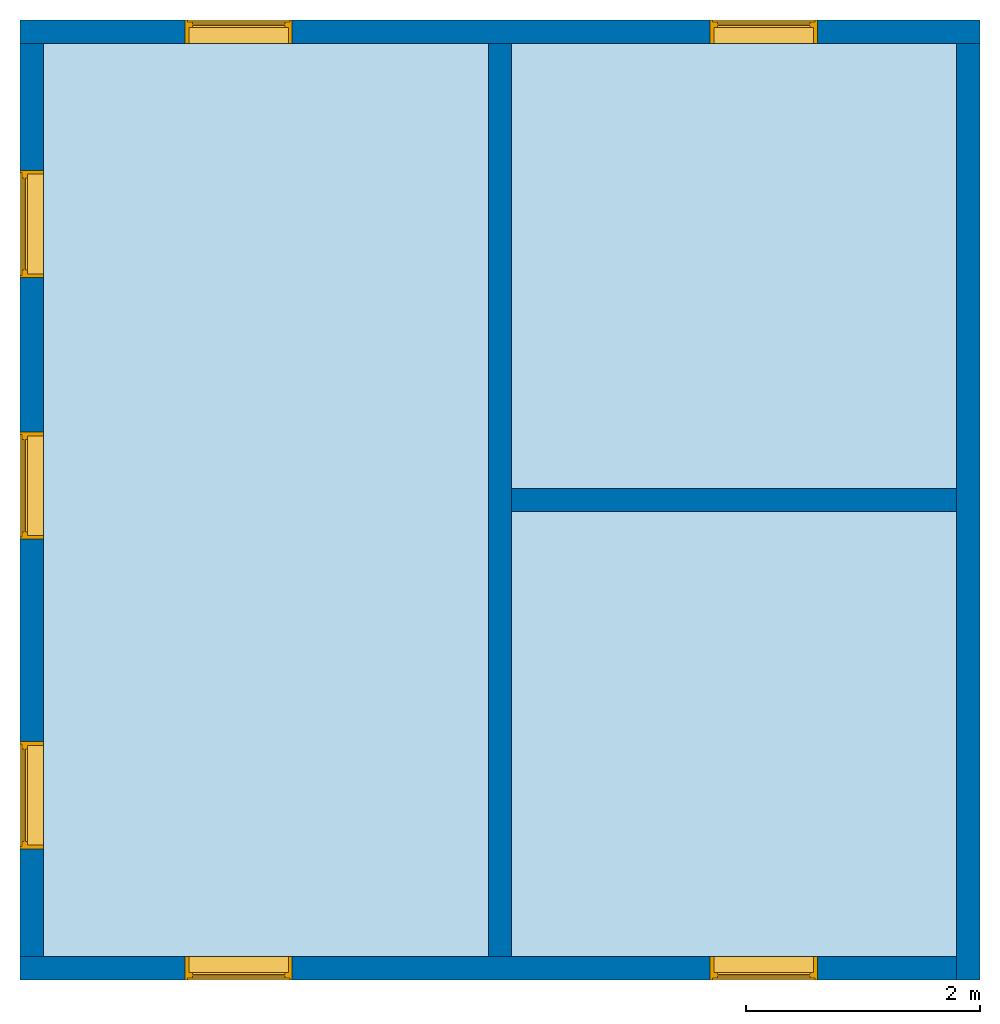
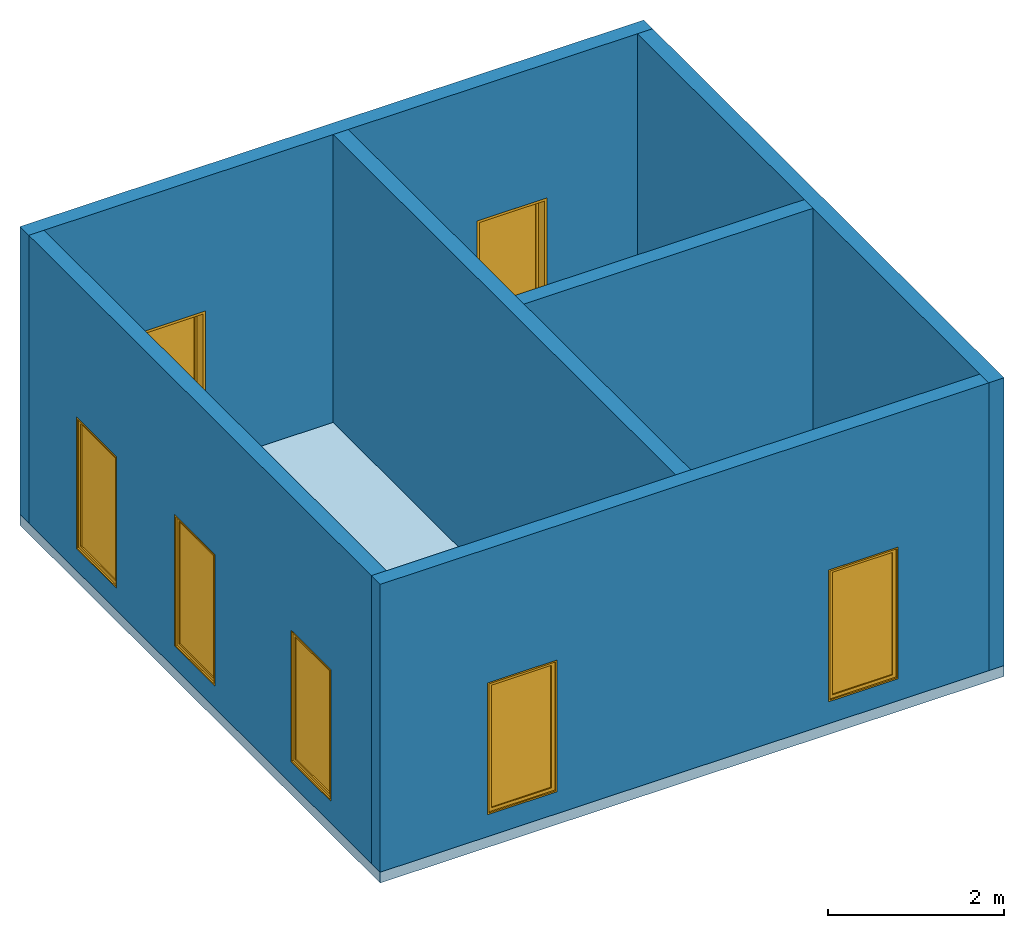
# One storey: 7 windows, 6 walls, 1 slab, 7 openings.
"""IFC2X3 building model written with IfcOpenShell, lengths in millimetres."""

from ifc_helpers import new_model, entity, si_unit, converted_unit, derived_unit, direction, frame, frame_2d, origin, place, context, subcontext, project, spatial, polyline, rectangle, outline, extrude, clip, halfspace, source, transform, mapped, material, material_list, layer, layer_set, layer_usage, type_object, type_shapes, element, fill, save


model = new_model("IFC2X3")

# Units and contexts
model_context = context("Model", 3, precision=0.01, world=origin(), true_north=direction((6.12303176911189e-17, 1.0)))
body_context = subcontext(model_context, "Body", "Model", "MODEL_VIEW")
ifc_project = project(units=[si_unit("LENGTHUNIT", "METRE", prefix="MILLI"), si_unit("AREAUNIT", "SQUARE_METRE"), si_unit("VOLUMEUNIT", "CUBIC_METRE"), converted_unit("PLANEANGLEUNIT", "DEGREE", entity("IfcRatioMeasure", 0.0174532925199433), si_unit("PLANEANGLEUNIT", "RADIAN"), dimensions=[0, 0, 0, 0, 0, 0, 0]), si_unit("MASSUNIT", "GRAM", prefix="KILO"), derived_unit("MASSDENSITYUNIT", [(si_unit("MASSUNIT", "GRAM", prefix="KILO"), 1), (si_unit("LENGTHUNIT", "METRE"), -3)]), derived_unit("MOMENTOFINERTIAUNIT", [(si_unit("LENGTHUNIT", "METRE"), 4)]), si_unit("TIMEUNIT", "SECOND"), si_unit("FREQUENCYUNIT", "HERTZ"), si_unit("THERMODYNAMICTEMPERATUREUNIT", "DEGREE_CELSIUS"), derived_unit("THERMALTRANSMITTANCEUNIT", [(si_unit("MASSUNIT", "GRAM", prefix="KILO"), 1), (si_unit("THERMODYNAMICTEMPERATUREUNIT", "KELVIN"), -1), (si_unit("TIMEUNIT", "SECOND"), -3)]), derived_unit("VOLUMETRICFLOWRATEUNIT", [(si_unit("LENGTHUNIT", "METRE"), 3), (si_unit("TIMEUNIT", "SECOND"), -1)]), si_unit("ELECTRICCURRENTUNIT", "AMPERE"), si_unit("ELECTRICVOLTAGEUNIT", "VOLT"), si_unit("POWERUNIT", "WATT"), si_unit("FORCEUNIT", "NEWTON", prefix="KILO"), si_unit("ILLUMINANCEUNIT", "LUX"), si_unit("LUMINOUSFLUXUNIT", "LUMEN"), si_unit("LUMINOUSINTENSITYUNIT", "CANDELA"), derived_unit("USERDEFINED", [(si_unit("MASSUNIT", "GRAM", prefix="KILO"), -1), (si_unit("LENGTHUNIT", "METRE"), -2), (si_unit("TIMEUNIT", "SECOND"), 3), (si_unit("LUMINOUSFLUXUNIT", "LUMEN"), 1)]), derived_unit("LINEARVELOCITYUNIT", [(si_unit("LENGTHUNIT", "METRE"), 1), (si_unit("TIMEUNIT", "SECOND"), -1)]), si_unit("PRESSUREUNIT", "PASCAL"), derived_unit("USERDEFINED", [(si_unit("LENGTHUNIT", "METRE"), -2), (si_unit("MASSUNIT", "GRAM", prefix="KILO"), 1), (si_unit("TIMEUNIT", "SECOND"), -2)]), derived_unit("LINEARFORCEUNIT", [(si_unit("MASSUNIT", "GRAM", prefix="KILO"), 1), (si_unit("LENGTHUNIT", "METRE"), 1), (si_unit("TIMEUNIT", "SECOND"), -2), (si_unit("LENGTHUNIT", "METRE"), -1)]), derived_unit("PLANARFORCEUNIT", [(si_unit("MASSUNIT", "GRAM", prefix="KILO"), 1), (si_unit("LENGTHUNIT", "METRE"), 1), (si_unit("TIMEUNIT", "SECOND"), -2), (si_unit("LENGTHUNIT", "METRE"), -2)])], contexts=[model_context])

# Site, building, storey
site_placement = place(None, origin())
site = spatial("IfcSite", under=ifc_project, at=site_placement, CompositionType="ELEMENT")
building_placement = place(site_placement, origin())
building = spatial("IfcBuilding", under=site, at=building_placement, Name="// BUILDING/NAME //", CompositionType="ELEMENT")
storey_placement = place(building_placement, frame((0.0, 0.0, 4000.0)))
storey = spatial("IfcBuildingStorey", under=building, at=storey_placement, Name="Level 2", CompositionType="ELEMENT", Elevation=4000.0)

# Slab
ifc_material_1 = material(Name="Default Floor")
ifc_layer_1 = layer(ifc_material_1, 150.0)
ifc_layer_set_1 = layer_set([ifc_layer_1], Name="Floor:Generic 150mm")
ifc_layer_usage_1 = layer_usage(ifc_layer_set_1, "AXIS3", "POSITIVE", 0.0)
slab_type = type_object("IfcSlabType", Name="Floor:Generic 150mm", PredefinedType="FLOOR", material=ifc_layer_set_1)
slab_placement = place(storey_placement, origin())
element("IfcSlab", 1, at=slab_placement, inside=storey, type_object=slab_type, material=ifc_layer_usage_1, Name="Floor:Generic 150mm", ObjectType="Floor:Generic 150mm", PredefinedType="FLOOR", context=body_context, shape_type="SweptSolid", body=[
    extrude(rectangle(XDim=8200.0, YDim=8200.00000000004, at=frame_2d((0.0, -3.18323145620525e-12), x_axis=(1.0, 0.0))), frame((-1771.27800988199, -3876.69891580694, 0.0), z_axis=(0.0, 0.0, -1.0), x_axis=(0.0, 1.0, 0.0)), (0.0, 0.0, 1.0), 150.0),
])

# Wall, openings, windows
ifc_material_2 = material(Name="Default Wall")
ifc_layer_2 = layer(ifc_material_2, 200.0)
ifc_layer_set_2 = layer_set([ifc_layer_2], Name="Basic Wall:Outside wall")
ifc_layer_usage_2 = layer_usage(ifc_layer_set_2, "AXIS2", "NEGATIVE", 100.0)
wall_type_1 = type_object("IfcWallType", Name="Basic Wall:Outside wall", PredefinedType="STANDARD", material=ifc_layer_set_2)
wall_1_placement = place(storey_placement, frame((-5871.27800988201, 123.301084193077, 0.0)))
wall_1 = element("IfcWallStandardCase", 2, at=wall_1_placement, inside=storey, type_object=wall_type_1, material=ifc_layer_usage_2, Name="Basic Wall:Outside wall", ObjectType="Basic Wall:Outside wall", context=body_context, shape_type="Clipping", body=[
    clip(extrude(rectangle(XDim=8200.00000000003, YDim=200.0, at=frame_2d((4100.00000000002, 0.0), x_axis=(-1.0, 0.0))), origin(), (0.0, 0.0, 1.0), 4000.0), halfspace(frame((0.0, 0.0, -4000.0)), True)),
])
opening_1_placement = place(wall_1_placement, frame((1409.85378995122, -100.0, 305.0)))
opening_1 = element("IfcOpeningElement", 3, at=opening_1_placement, cuts=wall_1, Name="M_Fixed:0915 x 1830mm:1", ObjectType="Opening", context=body_context, shape_type="SweptSolid", body=[
    extrude(rectangle(XDim=1830.0, YDim=914.999999999999, at=frame_2d((914.999999999999, 457.5), x_axis=(1.0, 0.0))), frame((0.0, 0.0, 0.0), z_axis=(0.0, 1.0, 0.0), x_axis=(0.0, 0.0, 1.0)), (0.0, 0.0, 1.0), 200.0),
])
opening_2_placement = place(wall_1_placement, frame((5894.85378995126, -100.0, 305.0)))
opening_2 = element("IfcOpeningElement", 4, at=opening_2_placement, cuts=wall_1, Name="M_Fixed:0915 x 1830mm:1", ObjectType="Opening", context=body_context, shape_type="SweptSolid", body=[
    extrude(rectangle(XDim=1830.0, YDim=914.999999999999, at=frame_2d((914.999999999999, 457.499999999999), x_axis=(1.0, 0.0))), frame((0.0, 0.0, 0.0), z_axis=(0.0, 1.0, 0.0), x_axis=(0.0, 0.0, 1.0)), (0.0, 0.0, 1.0), 200.0),
])
ifc_material_3 = material(Name="Glass")
ifc_material_4 = material(Name="Sash")
ifc_material_list_1 = material_list([ifc_material_3, ifc_material_4])
ifc_material_list_2 = material_list([ifc_material_4, ifc_material_4, ifc_material_4, ifc_material_3])
window_style = type_object("IfcWindowStyle", Name="M_Fixed:0915 x 1830mm", ConstructionType="NOTDEFINED", OperationType="NOTDEFINED", ParameterTakesPrecedence=False, Sizeable=False, material=ifc_material_list_2)
shared_shape = source(origin(), body_context, "Body", "SweptSolid", [
    extrude(rectangle(XDim=12.0, YDim=788.999999999997, at=frame_2d((8.43769498715119e-15, 0.0), x_axis=(1.0, 0.0))), frame((457.500000000006, 159.0, 63.0), z_axis=(0.0, 0.0, 1.0), x_axis=(0.0, -1.0, 0.0)), (0.0, 0.0, 1.0), 1704.00000000001),
    extrude(outline(polyline([(-438.5, -896.0), (438.5, -896.0), (438.5, 896.0), (-438.5, 896.0), (-438.5, -896.0)]), holes=[polyline([(-394.5, -852.0), (-394.5, 852.0), (394.499999999998, 852.0), (394.499999999998, -852.0), (-394.5, -852.0)])]), frame((457.500000000007, 137.0, 915.0), z_axis=(0.0, 1.0, 0.0), x_axis=(1.0, 0.0, 0.0)), (0.0, 0.0, 1.0), 44.0000000000274),
    extrude(outline(polyline([(-457.5, -915.0), (457.5, -915.0), (457.5, 915.0), (-457.5, 915.0), (-457.5, -915.0)]), holes=[polyline([(-438.500000000001, -896.0), (-438.500000000001, 896.0), (438.499999999999, 896.0), (438.499999999999, -896.0), (-438.500000000001, -896.0)])]), frame((457.500000000008, 137.0, 915.0), z_axis=(0.0, 1.0, 0.0), x_axis=(1.0, 0.0, 0.0)), (0.0, 0.0, 1.0), 63.0000000000274),
    extrude(outline(polyline([(-457.5, -915.0), (457.5, -915.0), (457.5, 915.0), (-457.5, 915.0), (-457.5, -915.0)]), holes=[polyline([(-425.5, -883.0), (-425.5, 883.0), (425.5, 883.0), (425.5, -883.0), (-425.5, -883.0)])]), frame((457.500000000008, 0.0, 915.0), z_axis=(0.0, 1.0, 0.0), x_axis=(1.0, 0.0, 0.0)), (0.0, 0.0, 1.0), 136.999999999973),
])
type_shapes(window_style, [shared_shape])
window_1_placement = place(opening_1_placement, origin())
window_1 = element("IfcWindow", 5, at=window_1_placement, inside=storey, type_object=window_style, material=ifc_material_list_1, Name="M_Fixed:0915 x 1830mm", ObjectType="M_Fixed:0915 x 1830mm", OverallHeight=1830.0, OverallWidth=914.999999999999, context=body_context, shape_type="MappedRepresentation", body=[
    mapped(shared_shape, transform((0.0, 0.0, 0.0), scale=1.0)),
])
fill(opening_1, window_1)
ifc_material_list_3 = material_list([ifc_material_3, ifc_material_4])
window_2_placement = place(opening_2_placement, origin())
window_2 = element("IfcWindow", 6, at=window_2_placement, inside=storey, type_object=window_style, material=ifc_material_list_3, Name="M_Fixed:0915 x 1830mm", ObjectType="M_Fixed:0915 x 1830mm", OverallHeight=1830.0, OverallWidth=915.0, context=body_context, shape_type="MappedRepresentation", body=[
    mapped(shared_shape, transform((0.0, 0.0, 0.0), scale=1.0)),
])
fill(opening_2, window_2)

# Wall
ifc_layer_usage_3 = layer_usage(ifc_layer_set_2, "AXIS2", "NEGATIVE", 100.0)
wall_2_placement = place(storey_placement, frame((2228.72199011802, 23.3010841930509, 0.0), z_axis=(0.0, 0.0, 1.0), x_axis=(0.0, -1.0, 0.0)))
element("IfcWallStandardCase", 7, at=wall_2_placement, inside=storey, type_object=wall_type_1, material=ifc_layer_usage_3, Name="Basic Wall:Outside wall", ObjectType="Basic Wall:Outside wall", context=body_context, shape_type="Clipping", body=[
    clip(extrude(rectangle(XDim=8000.0, YDim=200.0, at=frame_2d((4000.0, 0.0), x_axis=(-1.0, 0.0))), origin(), (0.0, 0.0, 1.0), 4000.0), halfspace(frame((0.0, 0.0, -4000.0)), True)),
])

# Wall, openings, windows
ifc_layer_usage_4 = layer_usage(ifc_layer_set_2, "AXIS2", "NEGATIVE", 100.0)
wall_3_placement = place(storey_placement, frame((2128.72199011802, -7876.69891580695, 0.0), z_axis=(0.0, 0.0, 1.0), x_axis=(-1.0, 0.0, 0.0)))
wall_3 = element("IfcWallStandardCase", 8, at=wall_3_placement, inside=storey, type_object=wall_type_1, material=ifc_layer_usage_4, Name="Basic Wall:Outside wall", ObjectType="Basic Wall:Outside wall", context=body_context, shape_type="Clipping", body=[
    clip(extrude(rectangle(XDim=8000.00000000005, YDim=200.0, at=frame_2d((4000.00000000002, 0.0), x_axis=(-1.0, 0.0))), origin(), (0.0, 0.0, 1.0), 4000.0), halfspace(frame((0.0, 0.0, -4000.0)), True)),
])
opening_3_placement = place(wall_3_placement, frame((5675.14621004882, -100.0, 305.0)))
opening_3 = element("IfcOpeningElement", 9, at=opening_3_placement, cuts=wall_3, Name="M_Fixed:0915 x 1830mm:1", ObjectType="Opening", context=body_context, shape_type="SweptSolid", body=[
    extrude(rectangle(XDim=1830.0, YDim=914.999999999999, at=frame_2d((914.999999999999, 457.499999999999), x_axis=(1.0, 0.0))), frame((0.0, 0.0, 0.0), z_axis=(0.0, 1.0, 0.0), x_axis=(0.0, 0.0, 1.0)), (0.0, 0.0, 1.0), 200.0),
])
opening_4_placement = place(wall_3_placement, frame((1190.14621004878, -100.0, 305.0)))
opening_4 = element("IfcOpeningElement", 10, at=opening_4_placement, cuts=wall_3, Name="M_Fixed:0915 x 1830mm:1", ObjectType="Opening", context=body_context, shape_type="SweptSolid", body=[
    extrude(rectangle(XDim=1830.0, YDim=914.999999999999, at=frame_2d((914.999999999999, 457.5), x_axis=(1.0, 0.0))), frame((0.0, 0.0, 0.0), z_axis=(0.0, 1.0, 0.0), x_axis=(0.0, 0.0, 1.0)), (0.0, 0.0, 1.0), 200.0),
])
ifc_material_list_4 = material_list([ifc_material_3, ifc_material_4])
window_3_placement = place(opening_3_placement, origin())
window_3 = element("IfcWindow", 11, at=window_3_placement, inside=storey, type_object=window_style, material=ifc_material_list_4, Name="M_Fixed:0915 x 1830mm", ObjectType="M_Fixed:0915 x 1830mm", OverallHeight=1830.0, OverallWidth=914.999999999999, context=body_context, shape_type="MappedRepresentation", body=[
    mapped(shared_shape, transform((0.0, 0.0, 0.0), scale=1.0)),
])
fill(opening_3, window_3)
ifc_material_list_5 = material_list([ifc_material_3, ifc_material_4])
window_4_placement = place(opening_4_placement, origin())
window_4 = element("IfcWindow", 12, at=window_4_placement, inside=storey, type_object=window_style, material=ifc_material_list_5, Name="M_Fixed:0915 x 1830mm", ObjectType="M_Fixed:0915 x 1830mm", OverallHeight=1830.0, OverallWidth=914.999999999999, context=body_context, shape_type="MappedRepresentation", body=[
    mapped(shared_shape, transform((0.0, 0.0, 0.0), scale=1.0)),
])
fill(opening_4, window_4)

ifc_layer_usage_5 = layer_usage(ifc_layer_set_2, "AXIS2", "NEGATIVE", 100.0)
wall_4_placement = place(storey_placement, frame((-5771.27800988202, -7776.69891580692, 0.0), z_axis=(0.0, 0.0, 1.0), x_axis=(0.0, 1.0, 0.0)))
wall_4 = element("IfcWallStandardCase", 13, at=wall_4_placement, inside=storey, type_object=wall_type_1, material=ifc_layer_usage_5, Name="Basic Wall:Outside wall", ObjectType="Basic Wall:Outside wall", context=body_context, shape_type="Clipping", body=[
    clip(extrude(rectangle(XDim=7800.0, YDim=200.0, at=frame_2d((3900.0, -1.56319401867222e-13), x_axis=(-1.0, 0.0))), origin(), (0.0, 0.0, 1.0), 4000.0), halfspace(frame((0.0, 0.0, -4000.0)), True)),
])
opening_5_placement = place(wall_4_placement, frame((5800.47543466347, -100.0, 305.0)))
opening_5 = element("IfcOpeningElement", 14, at=opening_5_placement, cuts=wall_4, Name="M_Fixed:0915 x 1830mm:1", ObjectType="Opening", context=body_context, shape_type="SweptSolid", body=[
    extrude(rectangle(XDim=1830.0, YDim=914.999999999999, at=frame_2d((914.999999999999, 457.5), x_axis=(1.0, 0.0))), frame((0.0, 0.0, 0.0), z_axis=(0.0, 1.0, 0.0), x_axis=(0.0, 0.0, 1.0)), (0.0, 0.0, 1.0), 200.0),
])
opening_6_placement = place(wall_4_placement, frame((920.475434663471, -100.0, 305.0)))
opening_6 = element("IfcOpeningElement", 15, at=opening_6_placement, cuts=wall_4, Name="M_Fixed:0915 x 1830mm:1", ObjectType="Opening", context=body_context, shape_type="SweptSolid", body=[
    extrude(rectangle(XDim=1830.0, YDim=914.999999999999, at=frame_2d((914.999999999999, 457.5), x_axis=(1.0, 0.0))), frame((0.0, 0.0, 0.0), z_axis=(0.0, 1.0, 0.0), x_axis=(0.0, 0.0, 1.0)), (0.0, 0.0, 1.0), 200.0),
])
opening_7_placement = place(wall_4_placement, frame((3565.0, -100.0, 305.0)))
opening_7 = element("IfcOpeningElement", 16, at=opening_7_placement, cuts=wall_4, Name="M_Fixed:0915 x 1830mm:1", ObjectType="Opening", context=body_context, shape_type="SweptSolid", body=[
    extrude(rectangle(XDim=1830.0, YDim=914.999999999999, at=frame_2d((914.999999999999, 457.5), x_axis=(1.0, 0.0))), frame((0.0, 0.0, 0.0), z_axis=(0.0, 1.0, 0.0), x_axis=(0.0, 0.0, 1.0)), (0.0, 0.0, 1.0), 200.0),
])
ifc_material_list_6 = material_list([ifc_material_3, ifc_material_4])
window_5_placement = place(opening_5_placement, origin())
window_5 = element("IfcWindow", 17, at=window_5_placement, inside=storey, type_object=window_style, material=ifc_material_list_6, Name="M_Fixed:0915 x 1830mm", ObjectType="M_Fixed:0915 x 1830mm", OverallHeight=1830.0, OverallWidth=915.0, context=body_context, shape_type="MappedRepresentation", body=[
    mapped(shared_shape, transform((0.0, 0.0, 0.0), scale=1.0)),
])
fill(opening_5, window_5)
ifc_material_list_7 = material_list([ifc_material_3, ifc_material_4])
window_6_placement = place(opening_6_placement, origin())
window_6 = element("IfcWindow", 18, at=window_6_placement, inside=storey, type_object=window_style, material=ifc_material_list_7, Name="M_Fixed:0915 x 1830mm", ObjectType="M_Fixed:0915 x 1830mm", OverallHeight=1830.0, OverallWidth=915.0, context=body_context, shape_type="MappedRepresentation", body=[
    mapped(shared_shape, transform((0.0, 0.0, 0.0), scale=1.0)),
])
fill(opening_6, window_6)
ifc_material_list_8 = material_list([ifc_material_3, ifc_material_4])
window_7_placement = place(opening_7_placement, origin())
window_7 = element("IfcWindow", 19, at=window_7_placement, inside=storey, type_object=window_style, material=ifc_material_list_8, Name="M_Fixed:0915 x 1830mm", ObjectType="M_Fixed:0915 x 1830mm", OverallHeight=1830.0, OverallWidth=914.999999999999, context=body_context, shape_type="MappedRepresentation", body=[
    mapped(shared_shape, transform((0.0, 0.0, 0.0), scale=1.0)),
])
fill(opening_7, window_7)

# Walls
ifc_layer_3 = layer(ifc_material_2, 200.0)
ifc_layer_set_3 = layer_set([ifc_layer_3], Name="Basic Wall:Inside")
ifc_layer_usage_6 = layer_usage(ifc_layer_set_3, "AXIS2", "NEGATIVE", 100.0)
wall_type_2 = type_object("IfcWallType", Name="Basic Wall:Inside", PredefinedType="STANDARD", material=ifc_layer_set_3)
wall_5_placement = place(storey_placement, frame((-1771.27800988198, 23.3010841930636, 0.0), z_axis=(0.0, 0.0, 1.0), x_axis=(0.0, -1.0, 0.0)))
element("IfcWallStandardCase", 20, at=wall_5_placement, inside=storey, type_object=wall_type_2, material=ifc_layer_usage_6, Name="Basic Wall:Inside", ObjectType="Basic Wall:Inside", context=body_context, shape_type="Clipping", body=[
    clip(extrude(rectangle(XDim=7800.0, YDim=200.0, at=frame_2d((3900.0, 1.13686837721616e-13), x_axis=(-1.0, 0.0))), origin(), (0.0, 0.0, 1.0), 4000.0), halfspace(frame((0.0, 0.0, -4000.0)), True)),
])
ifc_layer_usage_7 = layer_usage(ifc_layer_set_3, "AXIS2", "NEGATIVE", 100.0)
wall_6_placement = place(storey_placement, frame((-1671.27800988198, -3876.69891580694, 0.0)))
element("IfcWallStandardCase", 21, at=wall_6_placement, inside=storey, type_object=wall_type_2, material=ifc_layer_usage_7, Name="Basic Wall:Inside", ObjectType="Basic Wall:Inside", context=body_context, shape_type="Clipping", body=[
    clip(extrude(rectangle(XDim=3800.00000000001, YDim=200.0, at=frame_2d((1900.0, 2.20268248085631e-13), x_axis=(-1.0, 0.0))), origin(), (0.0, 0.0, 1.0), 4000.0), halfspace(frame((0.0, 0.0, -4000.0)), True)),
])

save(model, "model.ifc")
